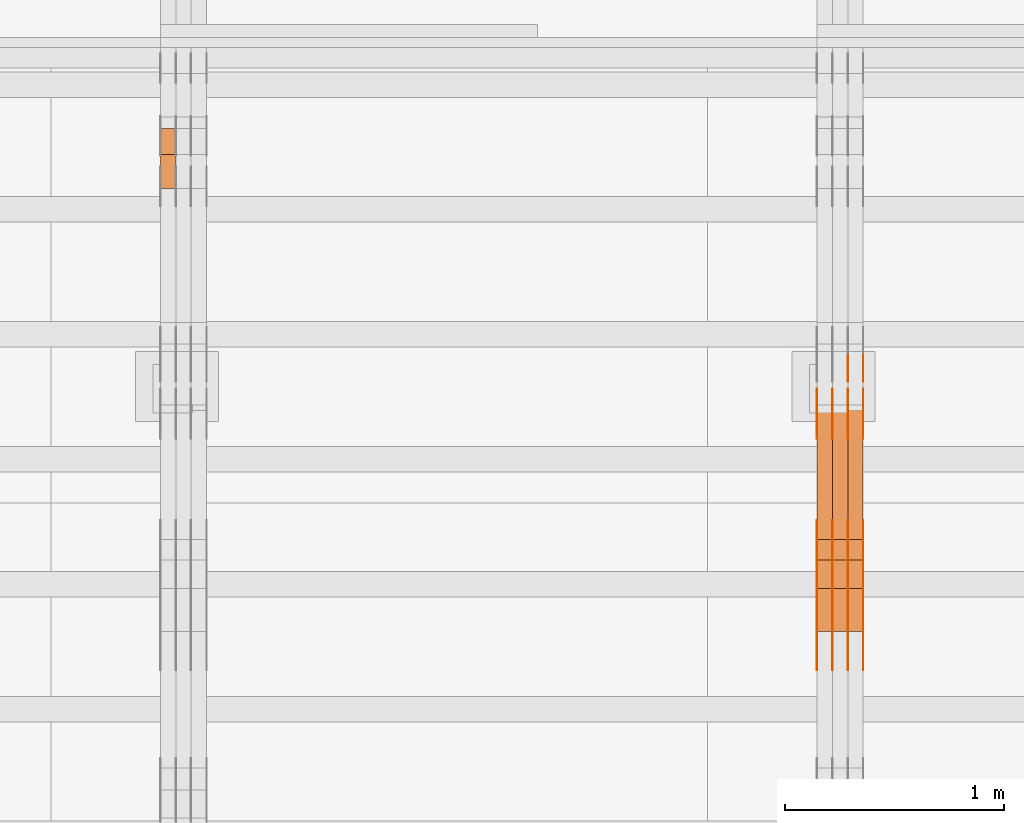
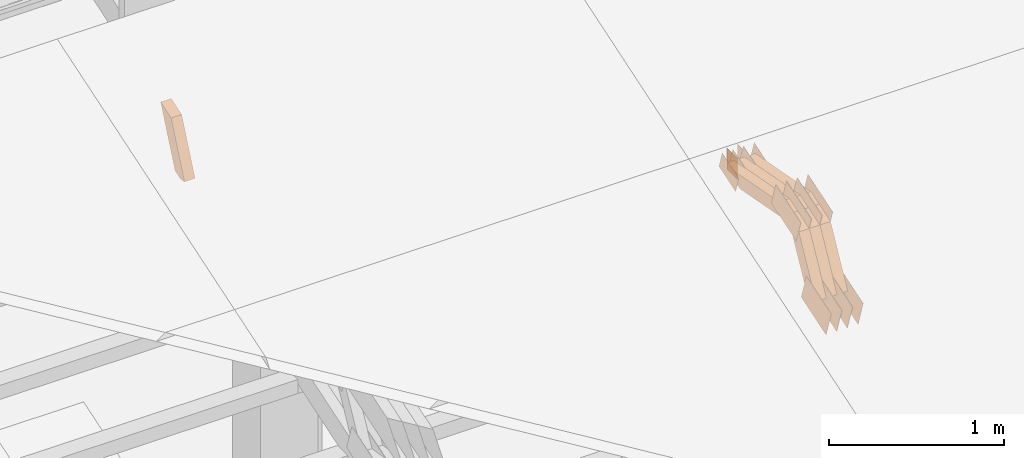
# One storey, part 93 of 385: 28 proxies.
"""IFC2X3 building model written with IfcOpenShell, lengths in millimetres."""

import ifcopenshell
import ifcopenshell.guid

model = None  # the IFC model being written
_history = None  # IfcOwnerHistory: only IFC2X3 demands one
_inside = {}  # id of a spatial element -> (the spatial element, [elements in it])
_under = {}  # id of a project, library or spatial element -> (it, [spatial elements below it])
_declared = {}  # id of a project -> (the project, [libraries it declares])
_typed = {}  # id of a type object -> (the type object, [elements of that type])
_made_of = {}  # id of a material, layer set ... -> (it, [elements and type objects made of it])


def new_model(schema):
    """Start an empty IFC model of exactly this schema.

    Asked for "IFC4X3", IfcOpenShell would pick the latest addendum, in which some entities
    have other attributes; the version numbers below select the first issue.
    IFC2X3 requires an IfcOwnerHistory on every rooted entity: one is made here for all.
    """
    global model, _history
    if schema == "IFC4X3":
        model = ifcopenshell.file(schema_version=(4, 3, 0, 0))
    else:
        model = ifcopenshell.file(schema=schema)
    _inside.clear()
    _under.clear()
    _declared.clear()
    _typed.clear()
    _made_of.clear()
    _history = None
    if model.schema == "IFC2X3":
        org = make("IfcOrganization", Name="unknown")
        user = make(
            "IfcPersonAndOrganization",
            ThePerson=make("IfcPerson", FamilyName="unknown"),
            TheOrganization=org,
        )
        app = make(
            "IfcApplication",
            ApplicationDeveloper=org,
            Version="unknown",
            ApplicationFullName="unknown",
            ApplicationIdentifier="unknown",
        )
        _history = make(
            "IfcOwnerHistory",
            OwningUser=user,
            OwningApplication=app,
            ChangeAction="ADDED",
            CreationDate=0,
        )
    return model


def make(cls, **values):
    """One entity of the class cls with the attributes given. An attribute that is None is left unset."""
    return model.create_entity(
        cls, **{name: value for name, value in values.items() if value is not None}
    )


def entity(cls, *values):
    """Any entity or typed value of the class cls, its attributes in the order of the schema. None: left unset."""
    e = model.create_entity(cls)
    for i, value in enumerate(values):
        if value is not None:
            e[i] = value
    return e


def rooted(cls, **values):
    """An entity with a GlobalId (a new one), such as an element, a storey or a relation."""
    return make(cls, GlobalId=ifcopenshell.guid.new(), OwnerHistory=_history, **values)


def si_unit(unit_type, name, prefix=None):
    """IfcSIUnit, for example si_unit("LENGTHUNIT", "METRE", prefix="MILLI")."""
    return make("IfcSIUnit", UnitType=unit_type, Prefix=prefix, Name=name)


def converted_unit(unit_type, name, factor, base, dimensions=None, offset=None):
    """IfcConversionBasedUnit, such as the inch: factor (a typed value) times the base unit."""
    return make(
        "IfcConversionBasedUnit"
        if offset is None
        else "IfcConversionBasedUnitWithOffset",
        ConversionOffset=offset,
        Dimensions=None
        if dimensions is None
        else entity("IfcDimensionalExponents", *dimensions),
        UnitType=unit_type,
        Name=name,
        ConversionFactor=make(
            "IfcMeasureWithUnit", ValueComponent=factor, UnitComponent=base
        ),
    )


def derived_unit(unit_type, elements):
    """IfcDerivedUnit: a product of units, each with its exponent."""
    return make(
        "IfcDerivedUnit",
        Elements=[
            make("IfcDerivedUnitElement", Unit=unit, Exponent=power)
            for unit, power in elements
        ],
        UnitType=unit_type,
    )


def assignment(units):
    """IfcUnitAssignment: the units of a project."""
    return None if units is None else make("IfcUnitAssignment", Units=units)


def point(xyz):
    """IfcCartesianPoint."""
    return None if xyz is None else make("IfcCartesianPoint", Coordinates=xyz)


def direction(xyz):
    """IfcDirection."""
    return None if xyz is None else make("IfcDirection", DirectionRatios=xyz)


def frame(location, z_axis=None, x_axis=None):
    """IfcAxis2Placement3D, a coordinate frame: its origin and axes. An axis left out is left unset."""
    return make(
        "IfcAxis2Placement3D",
        Location=point(location),
        Axis=direction(z_axis),
        RefDirection=direction(x_axis),
    )


def frame_2d(location, x_axis=None):
    """IfcAxis2Placement2D, a coordinate frame in the plane: its origin and x axis."""
    return make(
        "IfcAxis2Placement2D", Location=point(location), RefDirection=direction(x_axis)
    )


def origin():
    """The frame at (0, 0, 0) with its axes left unset."""
    return frame((0.0, 0.0, 0.0))


def place(relative_to, where):
    """IfcLocalPlacement: puts the frame where relative to a parent placement (None: the world)."""
    return make(
        "IfcLocalPlacement", PlacementRelTo=relative_to, RelativePlacement=where
    )


def context(
    kind, dimensions, precision=None, world=None, true_north=None, identifier=None
):
    """IfcGeometricRepresentationContext, for example the 3D "Model" context."""
    return make(
        "IfcGeometricRepresentationContext",
        ContextIdentifier=identifier,
        ContextType=kind,
        CoordinateSpaceDimension=dimensions,
        Precision=precision,
        WorldCoordinateSystem=world,
        TrueNorth=true_north,
    )


def subcontext(parent, identifier, kind, view, scale=None):
    """IfcGeometricRepresentationSubContext, for example "Body" below "Model"."""
    return make(
        "IfcGeometricRepresentationSubContext",
        ContextIdentifier=identifier,
        ContextType=kind,
        ParentContext=parent,
        TargetScale=scale,
        TargetView=view,
    )


def project(units=None, contexts=None):
    """IfcProject with its units and contexts."""
    return rooted(
        "IfcProject",
        Name="project",
        RepresentationContexts=contexts,
        UnitsInContext=assignment(units),
    )


def spatial(cls, under=None, at=None, **own):
    """A site, building, storey or space (cls), placed at a placement, below another one or the project."""
    s = rooted(cls, ObjectPlacement=at, **own)
    if under is not None:
        _under.setdefault(under.id(), (under, []))[1].append(s)
    return s


def polyline(points):
    """IfcPolyline through the points."""
    return make("IfcPolyline", Points=[point(p) for p in points])


def profile(cls, at=None, kind="AREA", **sizes):
    """A parametric profile (cls). Its sizes go by their IFC names, for example OverallWidth=200.0."""
    return make(cls, ProfileType=kind, Position=at, **sizes)


def rectangle(**sizes):
    """IfcRectangleProfileDef."""
    return profile("IfcRectangleProfileDef", **sizes)


def outline(outer, holes=None, kind="AREA"):
    """IfcArbitraryClosedProfileDef: a profile drawn as a closed curve; with holes, ...WithVoids."""
    if holes is None:
        return make("IfcArbitraryClosedProfileDef", ProfileType=kind, OuterCurve=outer)
    return make(
        "IfcArbitraryProfileDefWithVoids",
        ProfileType=kind,
        OuterCurve=outer,
        InnerCurves=holes,
    )


def extrude(swept, where, along, depth):
    """IfcExtrudedAreaSolid: the profile swept, set in the frame where, extruded along a direction by depth."""
    return make(
        "IfcExtrudedAreaSolid",
        SweptArea=swept,
        Position=where,
        ExtrudedDirection=direction(along),
        Depth=depth,
    )


def shape(context_of_items, identifier, shape_type, items):
    """IfcShapeRepresentation: the items that make up one representation, for example the "Body"."""
    return make(
        "IfcShapeRepresentation",
        ContextOfItems=context_of_items,
        RepresentationIdentifier=identifier,
        RepresentationType=shape_type,
        Items=items,
    )


def source(mapping_origin, context_of_items, identifier, shape_type, items):
    """IfcRepresentationMap: a shape defined once, which mapped items show again and again."""
    return make(
        "IfcRepresentationMap",
        MappingOrigin=mapping_origin,
        MappedRepresentation=shape(context_of_items, identifier, shape_type, items),
    )


def transform(
    local_origin,
    x_axis=None,
    y_axis=None,
    z_axis=None,
    scale=None,
    scale2=None,
    scale3=None,
    uniform=True,
):
    """IfcCartesianTransformationOperator3D, or its non-uniform kind. x_axis, y_axis, z_axis: its Axis1, 2, 3."""
    if uniform:
        return make(
            "IfcCartesianTransformationOperator3D",
            Axis1=direction(x_axis),
            Axis2=direction(y_axis),
            LocalOrigin=point(local_origin),
            Scale=scale,
            Axis3=direction(z_axis),
        )
    return make(
        "IfcCartesianTransformationOperator3DnonUniform",
        Axis1=direction(x_axis),
        Axis2=direction(y_axis),
        LocalOrigin=point(local_origin),
        Scale=scale,
        Axis3=direction(z_axis),
        Scale2=scale2,
        Scale3=scale3,
    )


def mapped(mapping_source, mapping_target):
    """IfcMappedItem: shows the shape of a source again, moved by a transform."""
    return make(
        "IfcMappedItem", MappingSource=mapping_source, MappingTarget=mapping_target
    )


def material(Name=None, Category=None):
    """IfcMaterial."""
    return make("IfcMaterial", Name=Name, Category=Category)


def made_of(thing, what):
    """Note that an element or type object is made of a material, layer set ...; save() writes the relation."""
    if what is not None:
        _made_of.setdefault(what.id(), (what, []))[1].append(thing)
    return thing


def type_object(cls, material=None, **own):
    """A type object (cls), such as IfcWallType, which elements share."""
    return made_of(rooted(cls, **own), material)


def type_shapes(of_type, sources):
    """Give a type object the sources (RepresentationMaps) that its elements show as mapped items."""
    of_type.RepresentationMaps = sources


def element(
    cls,
    number,
    at=None,
    inside=None,
    cuts=None,
    type_object=None,
    material=None,
    context=None,
    identifier="Body",
    shape_type=None,
    held_by="IfcProductDefinitionShape",
    body=None,
    shapes=None,
    **own,
):
    """One element of the class cls, such as IfcWall. Its Tag is "e" and its number.

    at: its placement. inside: the storey or other place that contains it. cuts: it is an
    opening in that element (IfcRelVoidsElement). A single representation is given by context,
    identifier, shape_type and body (its items); several are given by shapes. held_by: the class
    of the entity that holds the representations. save() writes the other relations.
    """
    e = rooted(cls, Tag="e%d" % number, ObjectPlacement=at, **own)
    if body is not None:
        shapes = [shape(context, identifier, shape_type, body)]
    if shapes is not None:
        e.Representation = make(held_by, Representations=shapes)
    if inside is not None:
        _inside.setdefault(inside.id(), (inside, []))[1].append(e)
    if cuts is not None:
        rooted(
            "IfcRelVoidsElement", RelatingBuildingElement=cuts, RelatedOpeningElement=e
        )
    if type_object is not None:
        _typed.setdefault(type_object.id(), (type_object, []))[1].append(e)
    return made_of(e, material)


def aggregate(whole, parts):
    """IfcRelAggregates: a whole, such as a stair, and the parts it consists of."""
    return rooted("IfcRelAggregates", RelatingObject=whole, RelatedObjects=parts)


def save(model, path):
    """Write the relations noted so far, then the file.

    IfcRelAggregates (storeys below a building ...), IfcRelContainedInSpatialStructure (elements
    in a storey), IfcRelDefinesByType, IfcRelAssociatesMaterial and IfcRelDeclares: one each for
    every whole, place, type object, material and project.
    """
    for whole, parts in _under.values():
        aggregate(whole, parts)
    for where, things in _inside.values():
        rooted(
            "IfcRelContainedInSpatialStructure",
            RelatedElements=things,
            RelatingStructure=where,
        )
    for kind, things in _typed.values():
        rooted("IfcRelDefinesByType", RelatedObjects=things, RelatingType=kind)
    for what, things in _made_of.values():
        rooted("IfcRelAssociatesMaterial", RelatedObjects=things, RelatingMaterial=what)
    for by, libraries in _declared.values():
        rooted("IfcRelDeclares", RelatingContext=by, RelatedDefinitions=libraries)
    model.write(path)


model = new_model("IFC2X3")

# Units and contexts
model_context = context("Model", 3, precision=0.01, world=origin(), true_north=direction((6.12303176911189e-17, 1.0)))
body_context = subcontext(model_context, "Body", "Model", "MODEL_VIEW")
ifc_project = project(units=[si_unit("LENGTHUNIT", "METRE", prefix="MILLI"), si_unit("AREAUNIT", "SQUARE_METRE"), si_unit("VOLUMEUNIT", "CUBIC_METRE"), converted_unit("PLANEANGLEUNIT", "DEGREE", entity("IfcRatioMeasure", 0.0174532925199433), si_unit("PLANEANGLEUNIT", "RADIAN"), dimensions=[0, 0, 0, 0, 0, 0, 0]), si_unit("MASSUNIT", "GRAM", prefix="KILO"), derived_unit("MASSDENSITYUNIT", [(si_unit("MASSUNIT", "GRAM", prefix="KILO"), 1), (si_unit("LENGTHUNIT", "METRE"), -3)]), si_unit("TIMEUNIT", "SECOND"), si_unit("FREQUENCYUNIT", "HERTZ"), si_unit("THERMODYNAMICTEMPERATUREUNIT", "DEGREE_CELSIUS"), derived_unit("THERMALTRANSMITTANCEUNIT", [(si_unit("MASSUNIT", "GRAM", prefix="KILO"), 1), (si_unit("THERMODYNAMICTEMPERATUREUNIT", "KELVIN"), -1), (si_unit("TIMEUNIT", "SECOND"), -3)]), derived_unit("VOLUMETRICFLOWRATEUNIT", [(si_unit("LENGTHUNIT", "METRE"), 3), (si_unit("TIMEUNIT", "SECOND"), -1)]), si_unit("ELECTRICCURRENTUNIT", "AMPERE"), si_unit("ELECTRICVOLTAGEUNIT", "VOLT"), si_unit("POWERUNIT", "WATT"), si_unit("FORCEUNIT", "NEWTON", prefix="KILO"), si_unit("ILLUMINANCEUNIT", "LUX"), si_unit("LUMINOUSFLUXUNIT", "LUMEN"), si_unit("LUMINOUSINTENSITYUNIT", "CANDELA"), derived_unit("USERDEFINED", [(si_unit("MASSUNIT", "GRAM", prefix="KILO"), -1), (si_unit("LENGTHUNIT", "METRE"), -2), (si_unit("TIMEUNIT", "SECOND"), 3), (si_unit("LUMINOUSFLUXUNIT", "LUMEN"), 1)]), derived_unit("LINEARVELOCITYUNIT", [(si_unit("LENGTHUNIT", "METRE"), 1), (si_unit("TIMEUNIT", "SECOND"), -1)]), si_unit("PRESSUREUNIT", "PASCAL"), derived_unit("USERDEFINED", [(si_unit("LENGTHUNIT", "METRE"), -2), (si_unit("MASSUNIT", "GRAM", prefix="KILO"), 1), (si_unit("TIMEUNIT", "SECOND"), -2)])], contexts=[model_context])

# Site, building, storey
site_placement = place(None, origin())
site = spatial("IfcSite", under=ifc_project, at=site_placement, CompositionType="ELEMENT")
building_placement = place(site_placement, origin())
building = spatial("IfcBuilding", under=site, at=building_placement, CompositionType="ELEMENT")
storey_placement = place(building_placement, origin())
storey = spatial("IfcBuildingStorey", under=building, at=storey_placement, Name="Default", CompositionType="ELEMENT", Elevation=0.0)

# Proxies
ifc_material_1 = material(Name="IfcSurfaceStyle #174024")
building_element_proxy_type_1 = type_object("IfcBuildingElementProxyType", PredefinedType="NOTDEFINED", material=ifc_material_1)
shared_shape_1 = source(origin(), body_context, "Body", "SweptSolid", [
    extrude(outline(polyline([(-149.99966632326, -95.9999759039407), (149.999881095801, -95.9999759039407), (150.000557367591, 95.9999759039407), (-150.000772140132, 95.9999759039406), (-149.99966632326, -95.9999759039407)])), frame((150.000557367591, 96.0004291135906, 0.0), z_axis=(0.0, 0.0, 1.0), x_axis=(-1.0, 0.0, 0.0)), (0.0, 0.0, 1.0), 1.29999999999999),
])
type_shapes(building_element_proxy_type_1, [shared_shape_1])
proxy_1_placement = place(building_placement, frame((12386.3, 10934.7734375, 2766.8759765625), z_axis=(-1.0, 0.0, 0.0), x_axis=(0.0, 0.951056516295124, 0.309016994375039)))
element("IfcBuildingElementProxy", 1, at=proxy_1_placement, inside=storey, type_object=building_element_proxy_type_1, material=ifc_material_1, context=body_context, shape_type="MappedRepresentation", body=[
    mapped(shared_shape_1, transform((0.0, 0.0, 0.0), scale=1.0)),
])
ifc_material_2 = material(Name="IfcSurfaceStyle #173967")
building_element_proxy_type_2 = type_object("IfcBuildingElementProxyType", PredefinedType="NOTDEFINED", material=ifc_material_2)
shared_shape_2 = source(origin(), body_context, "Body", "SweptSolid", [
    extrude(outline(polyline([(-149.99966632326, -95.9999759039407), (149.999881095801, -95.9999759039407), (150.000557367591, 95.9999759039407), (-150.000772140132, 95.9999759039406), (-149.99966632326, -95.9999759039407)])), frame((150.000557367591, 96.0004291135906, 0.0), z_axis=(0.0, 0.0, 1.0), x_axis=(-1.0, 0.0, 0.0)), (0.0, 0.0, 1.0), 1.29999999999999),
])
type_shapes(building_element_proxy_type_2, [shared_shape_2])
proxy_2_placement = place(building_placement, frame((12315.0, 10934.7734375, 2766.8759765625), z_axis=(-1.0, 0.0, 0.0), x_axis=(0.0, 0.951056516295124, 0.309016994375039)))
element("IfcBuildingElementProxy", 2, at=proxy_2_placement, inside=storey, type_object=building_element_proxy_type_2, material=ifc_material_2, context=body_context, shape_type="MappedRepresentation", body=[
    mapped(shared_shape_2, transform((0.0, 0.0, 0.0), scale=1.0)),
])
ifc_material_3 = material(Name="IfcSurfaceStyle #173910")
building_element_proxy_type_3 = type_object("IfcBuildingElementProxyType", PredefinedType="NOTDEFINED", material=ifc_material_3)
shared_shape_3 = source(origin(), body_context, "Body", "SweptSolid", [
    extrude(outline(polyline([(-149.99966632326, -95.9999759039407), (149.999881095801, -95.9999759039407), (150.000557367591, 95.9999759039407), (-150.000772140132, 95.9999759039406), (-149.99966632326, -95.9999759039407)])), frame((150.000557367591, 96.0004291135906, 0.0), z_axis=(0.0, 0.0, 1.0), x_axis=(-1.0, 0.0, 0.0)), (0.0, 0.0, 1.0), 1.29999999999999),
])
type_shapes(building_element_proxy_type_3, [shared_shape_3])
proxy_3_placement = place(building_placement, frame((12316.3, 10934.7734375, 2766.8759765625), z_axis=(-1.0, 0.0, 0.0), x_axis=(0.0, 0.951056516295124, 0.309016994375039)))
element("IfcBuildingElementProxy", 3, at=proxy_3_placement, inside=storey, type_object=building_element_proxy_type_3, material=ifc_material_3, context=body_context, shape_type="MappedRepresentation", body=[
    mapped(shared_shape_3, transform((0.0, 0.0, 0.0), scale=1.0)),
])
ifc_material_4 = material(Name="IfcSurfaceStyle #173853")
building_element_proxy_type_4 = type_object("IfcBuildingElementProxyType", PredefinedType="NOTDEFINED", material=ifc_material_4)
shared_shape_4 = source(origin(), body_context, "Body", "SweptSolid", [
    extrude(outline(polyline([(-149.99966632326, -95.9999759039407), (149.999881095801, -95.9999759039407), (150.000557367591, 95.9999759039407), (-150.000772140132, 95.9999759039406), (-149.99966632326, -95.9999759039407)])), frame((150.000557367591, 96.0004291135906, 0.0), z_axis=(0.0, 0.0, 1.0), x_axis=(-1.0, 0.0, 0.0)), (0.0, 0.0, 1.0), 1.29999999999998),
])
type_shapes(building_element_proxy_type_4, [shared_shape_4])
proxy_4_placement = place(building_placement, frame((12245.0, 10934.7734375, 2766.8759765625), z_axis=(-1.0, 0.0, 0.0), x_axis=(0.0, 0.951056516295124, 0.309016994375039)))
element("IfcBuildingElementProxy", 4, at=proxy_4_placement, inside=storey, type_object=building_element_proxy_type_4, material=ifc_material_4, context=body_context, shape_type="MappedRepresentation", body=[
    mapped(shared_shape_4, transform((0.0, 0.0, 0.0), scale=1.0)),
])
ifc_material_5 = material(Name="IfcSurfaceStyle #173796")
building_element_proxy_type_5 = type_object("IfcBuildingElementProxyType", PredefinedType="NOTDEFINED", material=ifc_material_5)
shared_shape_5 = source(origin(), body_context, "Body", "SweptSolid", [
    extrude(outline(polyline([(-149.99966632326, -95.9999759039407), (149.999881095801, -95.9999759039407), (150.000557367591, 95.9999759039407), (-150.000772140132, 95.9999759039406), (-149.99966632326, -95.9999759039407)])), frame((150.000557367591, 96.0004291135906, 0.0), z_axis=(0.0, 0.0, 1.0), x_axis=(-1.0, 0.0, 0.0)), (0.0, 0.0, 1.0), 1.29999999999998),
])
type_shapes(building_element_proxy_type_5, [shared_shape_5])
proxy_5_placement = place(building_placement, frame((12246.3, 10934.7734375, 2766.8759765625), z_axis=(-1.0, 0.0, 0.0), x_axis=(0.0, 0.951056516295124, 0.309016994375039)))
element("IfcBuildingElementProxy", 5, at=proxy_5_placement, inside=storey, type_object=building_element_proxy_type_5, material=ifc_material_5, context=body_context, shape_type="MappedRepresentation", body=[
    mapped(shared_shape_5, transform((0.0, 0.0, 0.0), scale=1.0)),
])
ifc_material_6 = material(Name="IfcSurfaceStyle #173739")
building_element_proxy_type_6 = type_object("IfcBuildingElementProxyType", PredefinedType="NOTDEFINED", material=ifc_material_6)
shared_shape_6 = source(origin(), body_context, "Body", "SweptSolid", [
    extrude(outline(polyline([(-149.99966632326, -95.9999759039407), (149.999881095801, -95.9999759039407), (150.000557367591, 95.9999759039407), (-150.000772140132, 95.9999759039406), (-149.99966632326, -95.9999759039407)])), frame((150.000557367591, 96.0004291135906, 0.0), z_axis=(0.0, 0.0, 1.0), x_axis=(-1.0, 0.0, 0.0)), (0.0, 0.0, 1.0), 1.29999999999998),
])
type_shapes(building_element_proxy_type_6, [shared_shape_6])
proxy_6_placement = place(building_placement, frame((12175.0, 10934.7734375, 2766.8759765625), z_axis=(-1.0, 0.0, 0.0), x_axis=(0.0, 0.951056516295124, 0.309016994375039)))
element("IfcBuildingElementProxy", 6, at=proxy_6_placement, inside=storey, type_object=building_element_proxy_type_6, material=ifc_material_6, context=body_context, shape_type="MappedRepresentation", body=[
    mapped(shared_shape_6, transform((0.0, 0.0, 0.0), scale=1.0)),
])
ifc_material_7 = material(Name="IfcSurfaceStyle #172656")
building_element_proxy_type_7 = type_object("IfcBuildingElementProxyType", PredefinedType="NOTDEFINED", material=ifc_material_7)
shared_shape_7 = source(origin(), body_context, "Body", "SweptSolid", [
    extrude(outline(polyline([(-99.9997874178038, -60.0000528641967), (99.9998102700997, -60.0000528641967), (99.9998251396068, 60.0000528641967), (-99.9998479919027, 60.0000528641967), (-99.9997874178038, -60.0000528641967)])), frame((99.9999918898597, 60.0000528641967, 0.0), z_axis=(0.0, 0.0, 1.0), x_axis=(-1.0, 0.0, 0.0)), (0.0, 0.0, 1.0), 1.3),
])
type_shapes(building_element_proxy_type_7, [shared_shape_7])
proxy_7_placement = place(building_placement, frame((12386.3, 11991.9568177725, 3072.52282247925), z_axis=(-1.0, 0.0, 0.0), x_axis=(0.0, 0.951056516295124, 0.309016994375039)))
element("IfcBuildingElementProxy", 7, at=proxy_7_placement, inside=storey, type_object=building_element_proxy_type_7, material=ifc_material_7, context=body_context, shape_type="MappedRepresentation", body=[
    mapped(shared_shape_7, transform((0.0, 0.0, 0.0), scale=1.0)),
])
ifc_material_8 = material(Name="IfcSurfaceStyle #172599")
building_element_proxy_type_8 = type_object("IfcBuildingElementProxyType", PredefinedType="NOTDEFINED", material=ifc_material_8)
shared_shape_8 = source(origin(), body_context, "Body", "SweptSolid", [
    extrude(outline(polyline([(-99.9997874178038, -60.0000528641967), (99.9998102700997, -60.0000528641967), (99.9998251396068, 60.0000528641967), (-99.9998479919027, 60.0000528641967), (-99.9997874178038, -60.0000528641967)])), frame((99.9999918898597, 60.0000528641967, 0.0), z_axis=(0.0, 0.0, 1.0), x_axis=(-1.0, 0.0, 0.0)), (0.0, 0.0, 1.0), 1.3),
])
type_shapes(building_element_proxy_type_8, [shared_shape_8])
proxy_8_placement = place(building_placement, frame((12315.0, 11991.9568177725, 3072.52282247925), z_axis=(-1.0, 0.0, 0.0), x_axis=(0.0, 0.951056516295124, 0.309016994375039)))
element("IfcBuildingElementProxy", 8, at=proxy_8_placement, inside=storey, type_object=building_element_proxy_type_8, material=ifc_material_8, context=body_context, shape_type="MappedRepresentation", body=[
    mapped(shared_shape_8, transform((0.0, 0.0, 0.0), scale=1.0)),
])
ifc_material_9 = material(Name="IfcSurfaceStyle #172542")
building_element_proxy_type_9 = type_object("IfcBuildingElementProxyType", PredefinedType="NOTDEFINED", material=ifc_material_9)
shared_shape_9 = source(origin(), body_context, "Body", "SweptSolid", [
    extrude(outline(polyline([(-99.9997874178038, -60.0000528641967), (99.9998102700997, -60.0000528641967), (99.9998251396068, 60.0000528641967), (-99.9998479919027, 60.0000528641967), (-99.9997874178038, -60.0000528641967)])), frame((99.9999918898597, 60.0000528641967, 0.0), z_axis=(0.0, 0.0, 1.0), x_axis=(-1.0, 0.0, 0.0)), (0.0, 0.0, 1.0), 1.3),
])
type_shapes(building_element_proxy_type_9, [shared_shape_9])
proxy_9_placement = place(building_placement, frame((12316.3, 11991.9568177725, 3072.52282247925), z_axis=(-1.0, 0.0, 0.0), x_axis=(0.0, 0.951056516295124, 0.309016994375039)))
element("IfcBuildingElementProxy", 9, at=proxy_9_placement, inside=storey, type_object=building_element_proxy_type_9, material=ifc_material_9, context=body_context, shape_type="MappedRepresentation", body=[
    mapped(shared_shape_9, transform((0.0, 0.0, 0.0), scale=1.0)),
])
ifc_material_10 = material(Name="IfcSurfaceStyle #172485")
building_element_proxy_type_10 = type_object("IfcBuildingElementProxyType", PredefinedType="NOTDEFINED", material=ifc_material_10)
shared_shape_10 = source(origin(), body_context, "Body", "SweptSolid", [
    extrude(outline(polyline([(-99.9997874178038, -60.0000528641967), (99.9998102700997, -60.0000528641967), (99.9998251396068, 60.0000528641967), (-99.9998479919027, 60.0000528641967), (-99.9997874178038, -60.0000528641967)])), frame((99.9999918898597, 60.0000528641967, 0.0), z_axis=(0.0, 0.0, 1.0), x_axis=(-1.0, 0.0, 0.0)), (0.0, 0.0, 1.0), 1.29999999999998),
])
type_shapes(building_element_proxy_type_10, [shared_shape_10])
proxy_10_placement = place(building_placement, frame((12245.0, 11991.9568177725, 3072.52282247925), z_axis=(-1.0, 0.0, 0.0), x_axis=(0.0, 0.951056516295124, 0.309016994375039)))
element("IfcBuildingElementProxy", 10, at=proxy_10_placement, inside=storey, type_object=building_element_proxy_type_10, material=ifc_material_10, context=body_context, shape_type="MappedRepresentation", body=[
    mapped(shared_shape_10, transform((0.0, 0.0, 0.0), scale=1.0)),
])
ifc_material_11 = material(Name="IfcSurfaceStyle #172428")
building_element_proxy_type_11 = type_object("IfcBuildingElementProxyType", PredefinedType="NOTDEFINED", material=ifc_material_11)
shared_shape_11 = source(origin(), body_context, "Body", "SweptSolid", [
    extrude(outline(polyline([(-99.9997874178038, -60.0000528641967), (99.9998102700997, -60.0000528641967), (99.9998251396068, 60.0000528641967), (-99.9998479919027, 60.0000528641967), (-99.9997874178038, -60.0000528641967)])), frame((99.9999918898597, 60.0000528641967, 0.0), z_axis=(0.0, 0.0, 1.0), x_axis=(-1.0, 0.0, 0.0)), (0.0, 0.0, 1.0), 1.29999999999998),
])
type_shapes(building_element_proxy_type_11, [shared_shape_11])
proxy_11_placement = place(building_placement, frame((12246.3, 11991.9568177725, 3072.52282247925), z_axis=(-1.0, 0.0, 0.0), x_axis=(0.0, 0.951056516295124, 0.309016994375039)))
element("IfcBuildingElementProxy", 11, at=proxy_11_placement, inside=storey, type_object=building_element_proxy_type_11, material=ifc_material_11, context=body_context, shape_type="MappedRepresentation", body=[
    mapped(shared_shape_11, transform((0.0, 0.0, 0.0), scale=1.0)),
])
ifc_material_12 = material(Name="IfcSurfaceStyle #172371")
building_element_proxy_type_12 = type_object("IfcBuildingElementProxyType", PredefinedType="NOTDEFINED", material=ifc_material_12)
shared_shape_12 = source(origin(), body_context, "Body", "SweptSolid", [
    extrude(outline(polyline([(-99.9997874178038, -60.0000528641967), (99.9998102700997, -60.0000528641967), (99.9998251396068, 60.0000528641967), (-99.9998479919027, 60.0000528641967), (-99.9997874178038, -60.0000528641967)])), frame((99.9999918898597, 60.0000528641967, 0.0), z_axis=(0.0, 0.0, 1.0), x_axis=(-1.0, 0.0, 0.0)), (0.0, 0.0, 1.0), 1.29999999999999),
])
type_shapes(building_element_proxy_type_12, [shared_shape_12])
proxy_12_placement = place(building_placement, frame((12175.0, 11991.9568177725, 3072.52282247925), z_axis=(-1.0, 0.0, 0.0), x_axis=(0.0, 0.951056516295124, 0.309016994375039)))
element("IfcBuildingElementProxy", 12, at=proxy_12_placement, inside=storey, type_object=building_element_proxy_type_12, material=ifc_material_12, context=body_context, shape_type="MappedRepresentation", body=[
    mapped(shared_shape_12, transform((0.0, 0.0, 0.0), scale=1.0)),
])
ifc_material_13 = material(Name="IfcSurfaceStyle #172314")
building_element_proxy_type_13 = type_object("IfcBuildingElementProxyType", PredefinedType="NOTDEFINED", material=ifc_material_13)
shared_shape_13 = source(origin(), body_context, "Body", "SweptSolid", [
    extrude(rectangle(XDim=150.0, YDim=119.999999999985, at=frame_2d((-7.105427357601e-15, 0.0), x_axis=(1.0, 0.0))), frame((75.0, 60.0, 0.0), z_axis=(0.0, 0.0, 1.0), x_axis=(-1.0, 0.0, 0.0)), (0.0, 0.0, 1.0), 1.3),
])
type_shapes(building_element_proxy_type_13, [shared_shape_13])
proxy_13_placement = place(building_placement, frame((12386.3, 12372.95703125, 3007.04687500001), z_axis=(-1.0, 0.0, 0.0), x_axis=(0.0, 0.0, -1.0)))
element("IfcBuildingElementProxy", 13, at=proxy_13_placement, inside=storey, type_object=building_element_proxy_type_13, material=ifc_material_13, context=body_context, shape_type="MappedRepresentation", body=[
    mapped(shared_shape_13, transform((0.0, 0.0, 0.0), scale=1.0)),
])
ifc_material_14 = material(Name="IfcSurfaceStyle #172257")
building_element_proxy_type_14 = type_object("IfcBuildingElementProxyType", PredefinedType="NOTDEFINED", material=ifc_material_14)
shared_shape_14 = source(origin(), body_context, "Body", "SweptSolid", [
    extrude(rectangle(XDim=150.0, YDim=119.999999999985, at=frame_2d((-7.105427357601e-15, 0.0), x_axis=(1.0, 0.0))), frame((75.0, 60.0, 0.0), z_axis=(0.0, 0.0, 1.0), x_axis=(-1.0, 0.0, 0.0)), (0.0, 0.0, 1.0), 1.3),
])
type_shapes(building_element_proxy_type_14, [shared_shape_14])
proxy_14_placement = place(building_placement, frame((12315.0, 12372.95703125, 3007.04687500001), z_axis=(-1.0, 0.0, 0.0), x_axis=(0.0, 0.0, -1.0)))
element("IfcBuildingElementProxy", 14, at=proxy_14_placement, inside=storey, type_object=building_element_proxy_type_14, material=ifc_material_14, context=body_context, shape_type="MappedRepresentation", body=[
    mapped(shared_shape_14, transform((0.0, 0.0, 0.0), scale=1.0)),
])
ifc_material_15 = material(Name="IfcSurfaceStyle #172200")
building_element_proxy_type_15 = type_object("IfcBuildingElementProxyType", PredefinedType="NOTDEFINED", material=ifc_material_15)
shared_shape_15 = source(origin(), body_context, "Body", "SweptSolid", [
    extrude(rectangle(XDim=150.0, YDim=119.999999999985, at=frame_2d((-7.105427357601e-15, 0.0), x_axis=(1.0, 0.0))), frame((75.0, 60.0, 0.0), z_axis=(0.0, 0.0, 1.0), x_axis=(-1.0, 0.0, 0.0)), (0.0, 0.0, 1.0), 1.3),
])
type_shapes(building_element_proxy_type_15, [shared_shape_15])
proxy_15_placement = place(building_placement, frame((12316.3, 12372.95703125, 3007.04687500001), z_axis=(-1.0, 0.0, 0.0), x_axis=(0.0, 0.0, -1.0)))
element("IfcBuildingElementProxy", 15, at=proxy_15_placement, inside=storey, type_object=building_element_proxy_type_15, material=ifc_material_15, context=body_context, shape_type="MappedRepresentation", body=[
    mapped(shared_shape_15, transform((0.0, 0.0, 0.0), scale=1.0)),
])
ifc_material_16 = material(Name="IfcSurfaceStyle #164448")
building_element_proxy_type_16 = type_object("IfcBuildingElementProxyType", PredefinedType="NOTDEFINED", material=ifc_material_16)
shared_shape_16 = source(origin(), body_context, "Body", "SweptSolid", [
    extrude(outline(polyline([(-150.000273478628, -84.0002987844282), (149.999198496832, -84.0002987844282), (150.000273478627, 84.0002987844282), (-149.999198496831, 84.0002987844282), (-150.000273478628, -84.0002987844282)])), frame((150.000273478627, 84.0002987844282, 0.0), z_axis=(0.0, 0.0, 1.0), x_axis=(-1.0, 0.0, 0.0)), (0.0, 0.0, 1.0), 1.29999999999999),
])
type_shapes(building_element_proxy_type_16, [shared_shape_16])
proxy_16_placement = place(building_placement, frame((12386.3, 11283.0116722926, 3194.09682266857), z_axis=(-1.0, 0.0, 0.0), x_axis=(0.0, 0.951056516295154, 0.309016994374948)))
element("IfcBuildingElementProxy", 16, at=proxy_16_placement, inside=storey, type_object=building_element_proxy_type_16, material=ifc_material_16, context=body_context, shape_type="MappedRepresentation", body=[
    mapped(shared_shape_16, transform((0.0, 0.0, 0.0), scale=1.0)),
])
ifc_material_17 = material(Name="IfcSurfaceStyle #164391")
building_element_proxy_type_17 = type_object("IfcBuildingElementProxyType", PredefinedType="NOTDEFINED", material=ifc_material_17)
shared_shape_17 = source(origin(), body_context, "Body", "SweptSolid", [
    extrude(outline(polyline([(-150.000273478628, -84.0002987844282), (149.999198496832, -84.0002987844282), (150.000273478627, 84.0002987844282), (-149.999198496831, 84.0002987844282), (-150.000273478628, -84.0002987844282)])), frame((150.000273478627, 84.0002987844282, 0.0), z_axis=(0.0, 0.0, 1.0), x_axis=(-1.0, 0.0, 0.0)), (0.0, 0.0, 1.0), 1.29999999999999),
])
type_shapes(building_element_proxy_type_17, [shared_shape_17])
proxy_17_placement = place(building_placement, frame((12315.0, 11283.0116722926, 3194.09682266857), z_axis=(-1.0, 0.0, 0.0), x_axis=(0.0, 0.951056516295154, 0.309016994374948)))
element("IfcBuildingElementProxy", 17, at=proxy_17_placement, inside=storey, type_object=building_element_proxy_type_17, material=ifc_material_17, context=body_context, shape_type="MappedRepresentation", body=[
    mapped(shared_shape_17, transform((0.0, 0.0, 0.0), scale=1.0)),
])
ifc_material_18 = material(Name="IfcSurfaceStyle #164334")
building_element_proxy_type_18 = type_object("IfcBuildingElementProxyType", PredefinedType="NOTDEFINED", material=ifc_material_18)
shared_shape_18 = source(origin(), body_context, "Body", "SweptSolid", [
    extrude(outline(polyline([(-150.000273478628, -84.0002987844282), (149.999198496832, -84.0002987844282), (150.000273478627, 84.0002987844282), (-149.999198496831, 84.0002987844282), (-150.000273478628, -84.0002987844282)])), frame((150.000273478627, 84.0002987844282, 0.0), z_axis=(0.0, 0.0, 1.0), x_axis=(-1.0, 0.0, 0.0)), (0.0, 0.0, 1.0), 1.29999999999999),
])
type_shapes(building_element_proxy_type_18, [shared_shape_18])
proxy_18_placement = place(building_placement, frame((12316.3, 11283.0116722926, 3194.09682266857), z_axis=(-1.0, 0.0, 0.0), x_axis=(0.0, 0.951056516295154, 0.309016994374948)))
element("IfcBuildingElementProxy", 18, at=proxy_18_placement, inside=storey, type_object=building_element_proxy_type_18, material=ifc_material_18, context=body_context, shape_type="MappedRepresentation", body=[
    mapped(shared_shape_18, transform((0.0, 0.0, 0.0), scale=1.0)),
])
ifc_material_19 = material(Name="IfcSurfaceStyle #164277")
building_element_proxy_type_19 = type_object("IfcBuildingElementProxyType", PredefinedType="NOTDEFINED", material=ifc_material_19)
shared_shape_19 = source(origin(), body_context, "Body", "SweptSolid", [
    extrude(outline(polyline([(-150.000273478628, -84.0002987844282), (149.999198496832, -84.0002987844282), (150.000273478627, 84.0002987844282), (-149.999198496831, 84.0002987844282), (-150.000273478628, -84.0002987844282)])), frame((150.000273478627, 84.0002987844282, 0.0), z_axis=(0.0, 0.0, 1.0), x_axis=(-1.0, 0.0, 0.0)), (0.0, 0.0, 1.0), 1.29999999999998),
])
type_shapes(building_element_proxy_type_19, [shared_shape_19])
proxy_19_placement = place(building_placement, frame((12245.0, 11283.0116722926, 3194.09682266857), z_axis=(-1.0, 0.0, 0.0), x_axis=(0.0, 0.951056516295154, 0.309016994374948)))
element("IfcBuildingElementProxy", 19, at=proxy_19_placement, inside=storey, type_object=building_element_proxy_type_19, material=ifc_material_19, context=body_context, shape_type="MappedRepresentation", body=[
    mapped(shared_shape_19, transform((0.0, 0.0, 0.0), scale=1.0)),
])
ifc_material_20 = material(Name="IfcSurfaceStyle #164220")
building_element_proxy_type_20 = type_object("IfcBuildingElementProxyType", PredefinedType="NOTDEFINED", material=ifc_material_20)
shared_shape_20 = source(origin(), body_context, "Body", "SweptSolid", [
    extrude(outline(polyline([(-150.000273478628, -84.0002987844282), (149.999198496832, -84.0002987844282), (150.000273478627, 84.0002987844282), (-149.999198496831, 84.0002987844282), (-150.000273478628, -84.0002987844282)])), frame((150.000273478627, 84.0002987844282, 0.0), z_axis=(0.0, 0.0, 1.0), x_axis=(-1.0, 0.0, 0.0)), (0.0, 0.0, 1.0), 1.29999999999998),
])
type_shapes(building_element_proxy_type_20, [shared_shape_20])
proxy_20_placement = place(building_placement, frame((12246.3, 11283.0116722926, 3194.09682266857), z_axis=(-1.0, 0.0, 0.0), x_axis=(0.0, 0.951056516295154, 0.309016994374948)))
element("IfcBuildingElementProxy", 20, at=proxy_20_placement, inside=storey, type_object=building_element_proxy_type_20, material=ifc_material_20, context=body_context, shape_type="MappedRepresentation", body=[
    mapped(shared_shape_20, transform((0.0, 0.0, 0.0), scale=1.0)),
])
ifc_material_21 = material(Name="IfcSurfaceStyle #164163")
building_element_proxy_type_21 = type_object("IfcBuildingElementProxyType", PredefinedType="NOTDEFINED", material=ifc_material_21)
shared_shape_21 = source(origin(), body_context, "Body", "SweptSolid", [
    extrude(outline(polyline([(-150.000273478628, -84.0002987844282), (149.999198496832, -84.0002987844282), (150.000273478627, 84.0002987844282), (-149.999198496831, 84.0002987844282), (-150.000273478628, -84.0002987844282)])), frame((150.000273478627, 84.0002987844282, 0.0), z_axis=(0.0, 0.0, 1.0), x_axis=(-1.0, 0.0, 0.0)), (0.0, 0.0, 1.0), 1.29999999999998),
])
type_shapes(building_element_proxy_type_21, [shared_shape_21])
proxy_21_placement = place(building_placement, frame((12175.0, 11283.0116722926, 3194.09682266857), z_axis=(-1.0, 0.0, 0.0), x_axis=(0.0, 0.951056516295154, 0.309016994374948)))
element("IfcBuildingElementProxy", 21, at=proxy_21_placement, inside=storey, type_object=building_element_proxy_type_21, material=ifc_material_21, context=body_context, shape_type="MappedRepresentation", body=[
    mapped(shared_shape_21, transform((0.0, 0.0, 0.0), scale=1.0)),
])
ifc_material_22 = material(Name="IfcSurfaceStyle #154152")
building_element_proxy_type_22 = type_object("IfcBuildingElementProxyType", Name="T1-W9 154150", PredefinedType="NOTDEFINED", material=ifc_material_22)
shared_shape_22 = source(origin(), body_context, "Body", "SweptSolid", [
    extrude(outline(polyline([(-287.457507623288, -47.5000268597988), (288.590479960635, -47.5000268597988), (273.55062971372, -2.33146189358546e-05), (186.625054999886, 47.5000385171083), (-461.308657050953, 47.5000385171083), (-287.457507623288, -47.5000268597988)])), frame((288.590945855618, 47.5000968036551, 0.0), z_axis=(0.0, 0.0, 1.0), x_axis=(-1.0, 0.0, 0.0)), (0.0, 0.0, 1.0), 70.0),
])
type_shapes(building_element_proxy_type_22, [shared_shape_22])
proxy_22_placement = place(building_placement, frame((12385.0, 11432.1200855376, 3205.63308612017), z_axis=(-1.0, 0.0, 0.0), x_axis=(0.0, 0.982760503514031, -0.184883186722992)))
element("IfcBuildingElementProxy", 22, at=proxy_22_placement, inside=storey, type_object=building_element_proxy_type_22, material=ifc_material_22, Name="T1-W9", context=body_context, shape_type="MappedRepresentation", body=[
    mapped(shared_shape_22, transform((0.0, 0.0, 0.0), scale=1.0)),
])
ifc_material_23 = material(Name="IfcSurfaceStyle #154086")
building_element_proxy_type_23 = type_object("IfcBuildingElementProxyType", Name="T1-W9 154084", PredefinedType="NOTDEFINED", material=ifc_material_23)
shared_shape_23 = source(origin(), body_context, "Body", "SweptSolid", [
    extrude(outline(polyline([(-287.457507623288, -47.5000268597988), (288.590479960635, -47.5000268597988), (273.55062971372, -2.33146189358546e-05), (186.625054999886, 47.5000385171083), (-461.308657050953, 47.5000385171083), (-287.457507623288, -47.5000268597988)])), frame((288.590945855618, 47.5000968036551, 0.0), z_axis=(0.0, 0.0, 1.0), x_axis=(-1.0, 0.0, 0.0)), (0.0, 0.0, 1.0), 70.0),
])
type_shapes(building_element_proxy_type_23, [shared_shape_23])
proxy_23_placement = place(building_placement, frame((12315.0, 11432.1200855376, 3205.63308612017), z_axis=(-1.0, 0.0, 0.0), x_axis=(0.0, 0.982760503514031, -0.184883186722992)))
element("IfcBuildingElementProxy", 23, at=proxy_23_placement, inside=storey, type_object=building_element_proxy_type_23, material=ifc_material_23, Name="T1-W9", context=body_context, shape_type="MappedRepresentation", body=[
    mapped(shared_shape_23, transform((0.0, 0.0, 0.0), scale=1.0)),
])
ifc_material_24 = material(Name="IfcSurfaceStyle #154020")
building_element_proxy_type_24 = type_object("IfcBuildingElementProxyType", Name="T1-W9 154018", PredefinedType="NOTDEFINED", material=ifc_material_24)
shared_shape_24 = source(origin(), body_context, "Body", "SweptSolid", [
    extrude(outline(polyline([(-287.457507623288, -47.5000268597988), (288.590479960635, -47.5000268597988), (273.55062971372, -2.33146189358546e-05), (186.625054999886, 47.5000385171083), (-461.308657050953, 47.5000385171083), (-287.457507623288, -47.5000268597988)])), frame((288.590945855618, 47.5000968036551, 0.0), z_axis=(0.0, 0.0, 1.0), x_axis=(-1.0, 0.0, 0.0)), (0.0, 0.0, 1.0), 70.0),
])
type_shapes(building_element_proxy_type_24, [shared_shape_24])
proxy_24_placement = place(building_placement, frame((12245.0, 11432.1200855376, 3205.63308612017), z_axis=(-1.0, 0.0, 0.0), x_axis=(0.0, 0.982760503514031, -0.184883186722992)))
element("IfcBuildingElementProxy", 24, at=proxy_24_placement, inside=storey, type_object=building_element_proxy_type_24, material=ifc_material_24, Name="T1-W9", context=body_context, shape_type="MappedRepresentation", body=[
    mapped(shared_shape_24, transform((0.0, 0.0, 0.0), scale=1.0)),
])
ifc_material_25 = material(Name="IfcSurfaceStyle #153756")
building_element_proxy_type_25 = type_object("IfcBuildingElementProxyType", Name="T1-W32 153754", PredefinedType="NOTDEFINED", material=ifc_material_25)
shared_shape_25 = source(origin(), body_context, "Body", "SweptSolid", [
    extrude(outline(polyline([(-312.414547135921, -47.5000544873059), (136.677011757652, -47.5000544873059), (186.250996577889, 0.000369497452627243), (202.753116295831, 47.4998697385796), (-213.26657749545, 47.4998697385796), (-312.414547135921, -47.5000544873059)])), frame((202.753376481939, 47.5001296985553, 0.0), z_axis=(0.0, 0.0, 1.0), x_axis=(-1.0, 0.0, 0.0)), (0.0, 0.0, 1.0), 70.0),
])
type_shapes(building_element_proxy_type_25, [shared_shape_25])
proxy_25_placement = place(building_placement, frame((12385.0, 11110.7808979007, 2747.18129017315), z_axis=(-1.0, 0.0, 0.0), x_axis=(0.0, 0.472919689385906, 0.881105537033526)))
element("IfcBuildingElementProxy", 25, at=proxy_25_placement, inside=storey, type_object=building_element_proxy_type_25, material=ifc_material_25, Name="T1-W32", context=body_context, shape_type="MappedRepresentation", body=[
    mapped(shared_shape_25, transform((0.0, 0.0, 0.0), scale=1.0)),
])
ifc_material_26 = material(Name="IfcSurfaceStyle #153690")
building_element_proxy_type_26 = type_object("IfcBuildingElementProxyType", Name="T1-W32 153688", PredefinedType="NOTDEFINED", material=ifc_material_26)
shared_shape_26 = source(origin(), body_context, "Body", "SweptSolid", [
    extrude(outline(polyline([(-312.414547135921, -47.5000544873059), (136.677011757652, -47.5000544873059), (186.250996577889, 0.000369497452627243), (202.753116295831, 47.4998697385796), (-213.26657749545, 47.4998697385796), (-312.414547135921, -47.5000544873059)])), frame((202.753376481939, 47.5001296985553, 0.0), z_axis=(0.0, 0.0, 1.0), x_axis=(-1.0, 0.0, 0.0)), (0.0, 0.0, 1.0), 70.0),
])
type_shapes(building_element_proxy_type_26, [shared_shape_26])
proxy_26_placement = place(building_placement, frame((12315.0, 11110.7808979007, 2747.18129017315), z_axis=(-1.0, 0.0, 0.0), x_axis=(0.0, 0.472919689385906, 0.881105537033526)))
element("IfcBuildingElementProxy", 26, at=proxy_26_placement, inside=storey, type_object=building_element_proxy_type_26, material=ifc_material_26, Name="T1-W32", context=body_context, shape_type="MappedRepresentation", body=[
    mapped(shared_shape_26, transform((0.0, 0.0, 0.0), scale=1.0)),
])
ifc_material_27 = material(Name="IfcSurfaceStyle #153624")
building_element_proxy_type_27 = type_object("IfcBuildingElementProxyType", Name="T1-W32 153622", PredefinedType="NOTDEFINED", material=ifc_material_27)
shared_shape_27 = source(origin(), body_context, "Body", "SweptSolid", [
    extrude(outline(polyline([(-312.414547135921, -47.5000544873059), (136.677011757652, -47.5000544873059), (186.250996577889, 0.000369497452627243), (202.753116295831, 47.4998697385796), (-213.26657749545, 47.4998697385796), (-312.414547135921, -47.5000544873059)])), frame((202.753376481939, 47.5001296985553, 0.0), z_axis=(0.0, 0.0, 1.0), x_axis=(-1.0, 0.0, 0.0)), (0.0, 0.0, 1.0), 70.0),
])
type_shapes(building_element_proxy_type_27, [shared_shape_27])
proxy_27_placement = place(building_placement, frame((12245.0, 11110.7808979007, 2747.18129017315), z_axis=(-1.0, 0.0, 0.0), x_axis=(0.0, 0.472919689385906, 0.881105537033526)))
element("IfcBuildingElementProxy", 27, at=proxy_27_placement, inside=storey, type_object=building_element_proxy_type_27, material=ifc_material_27, Name="T1-W32", context=body_context, shape_type="MappedRepresentation", body=[
    mapped(shared_shape_27, transform((0.0, 0.0, 0.0), scale=1.0)),
])
ifc_material_28 = material(Name="IfcSurfaceStyle #120776")
building_element_proxy_type_28 = type_object("IfcBuildingElementProxyType", Name="T1-W42 120774", PredefinedType="NOTDEFINED", material=ifc_material_28)
shared_shape_28 = source(origin(), body_context, "Body", "SweptSolid", [
    extrude(outline(polyline([(-284.837590197601, -47.4997543607933), (129.95880168156, -47.4997543607933), (171.972324990451, 0.000162623346093338), (183.717007105413, 47.4996730491203), (-200.810543579822, 47.4996730491203), (-284.837590197601, -47.4997543607933)])), frame((183.717155718752, 47.4999821655365, 0.0), z_axis=(0.0, 0.0, 1.0), x_axis=(-1.0, 0.0, 0.0)), (0.0, 0.0, 1.0), 70.0),
])
type_shapes(building_element_proxy_type_28, [shared_shape_28])
proxy_28_placement = place(building_placement, frame((9245.0, 13135.8834463264, 3404.958483022), z_axis=(-1.0, 0.0, 0.0), x_axis=(0.0, 0.398630596470292, 0.917111578575769)))
element("IfcBuildingElementProxy", 28, at=proxy_28_placement, inside=storey, type_object=building_element_proxy_type_28, material=ifc_material_28, Name="T1-W42", context=body_context, shape_type="MappedRepresentation", body=[
    mapped(shared_shape_28, transform((0.0, 0.0, 0.0), scale=1.0)),
])

save(model, "model.ifc")
